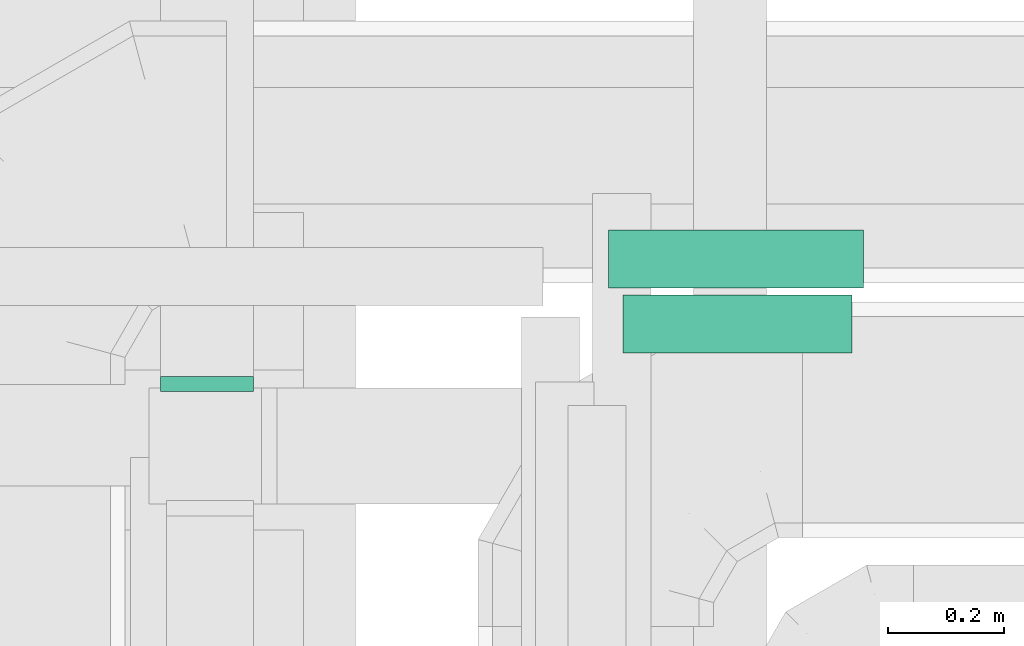
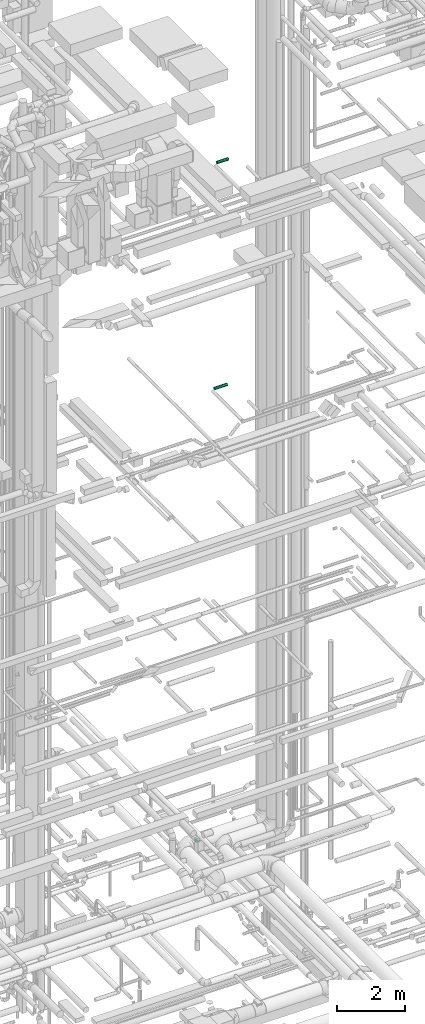
# One storey, part 268 of 337: 2 flow segments, 1 flow fitting.
"""IFC2X3 building model written with IfcOpenShell, lengths in millimetres."""

from ifc_helpers import new_model, entity, si_unit, converted_unit, derived_unit, direction, frame, origin, origin_2d_with_axis, place, context, subcontext, project, spatial, circle, extrude, faceted_brep, source, transform, mapped, material, type_object, type_shapes, element, save


model = new_model("IFC2X3")

# Units and contexts
model_context = context("Model", 3, precision=0.01, world=origin(), true_north=direction((6.12303176911189e-17, 1.0)))
body_context = subcontext(model_context, "Body", "Model", "MODEL_VIEW")
ifc_project = project(units=[si_unit("LENGTHUNIT", "METRE", prefix="MILLI"), si_unit("AREAUNIT", "SQUARE_METRE"), si_unit("VOLUMEUNIT", "CUBIC_METRE"), converted_unit("PLANEANGLEUNIT", "DEGREE", entity("IfcRatioMeasure", 0.0174532925199433), si_unit("PLANEANGLEUNIT", "RADIAN"), dimensions=[0, 0, 0, 0, 0, 0, 0]), si_unit("MASSUNIT", "GRAM", prefix="KILO"), derived_unit("MASSDENSITYUNIT", [(si_unit("MASSUNIT", "GRAM", prefix="KILO"), 1), (si_unit("LENGTHUNIT", "METRE"), -3)]), derived_unit("MOMENTOFINERTIAUNIT", [(si_unit("LENGTHUNIT", "METRE"), 4)]), si_unit("TIMEUNIT", "SECOND"), si_unit("FREQUENCYUNIT", "HERTZ"), si_unit("THERMODYNAMICTEMPERATUREUNIT", "DEGREE_CELSIUS"), derived_unit("THERMALTRANSMITTANCEUNIT", [(si_unit("MASSUNIT", "GRAM", prefix="KILO"), 1), (si_unit("THERMODYNAMICTEMPERATUREUNIT", "KELVIN"), -1), (si_unit("TIMEUNIT", "SECOND"), -3)]), derived_unit("VOLUMETRICFLOWRATEUNIT", [(si_unit("LENGTHUNIT", "METRE"), 3), (si_unit("TIMEUNIT", "SECOND"), -1)]), derived_unit("MASSFLOWRATEUNIT", [(si_unit("MASSUNIT", "GRAM", prefix="KILO"), 1), (si_unit("TIMEUNIT", "SECOND"), -1)]), derived_unit("ROTATIONALFREQUENCYUNIT", [(si_unit("TIMEUNIT", "SECOND"), -1)]), si_unit("ELECTRICCURRENTUNIT", "AMPERE"), si_unit("ELECTRICVOLTAGEUNIT", "VOLT"), si_unit("POWERUNIT", "WATT"), si_unit("FORCEUNIT", "NEWTON", prefix="KILO"), si_unit("ILLUMINANCEUNIT", "LUX"), si_unit("LUMINOUSFLUXUNIT", "LUMEN"), si_unit("LUMINOUSINTENSITYUNIT", "CANDELA"), derived_unit("USERDEFINED", [(si_unit("MASSUNIT", "GRAM", prefix="KILO"), -1), (si_unit("LENGTHUNIT", "METRE"), -2), (si_unit("TIMEUNIT", "SECOND"), 3), (si_unit("LUMINOUSFLUXUNIT", "LUMEN"), 1)]), derived_unit("LINEARVELOCITYUNIT", [(si_unit("LENGTHUNIT", "METRE"), 1), (si_unit("TIMEUNIT", "SECOND"), -1)]), si_unit("PRESSUREUNIT", "PASCAL"), derived_unit("USERDEFINED", [(si_unit("LENGTHUNIT", "METRE"), -2), (si_unit("MASSUNIT", "GRAM", prefix="KILO"), 1), (si_unit("TIMEUNIT", "SECOND"), -2)]), derived_unit("LINEARFORCEUNIT", [(si_unit("MASSUNIT", "GRAM", prefix="KILO"), 1), (si_unit("LENGTHUNIT", "METRE"), 1), (si_unit("TIMEUNIT", "SECOND"), -2), (si_unit("LENGTHUNIT", "METRE"), -1)]), derived_unit("PLANARFORCEUNIT", [(si_unit("MASSUNIT", "GRAM", prefix="KILO"), 1), (si_unit("LENGTHUNIT", "METRE"), 1), (si_unit("TIMEUNIT", "SECOND"), -2), (si_unit("LENGTHUNIT", "METRE"), -2)])], contexts=[model_context])

# Site, building, storey
site_placement = place(None, origin())
site = spatial("IfcSite", under=ifc_project, at=site_placement, CompositionType="ELEMENT")
building_placement = place(site_placement, origin())
building = spatial("IfcBuilding", under=site, at=building_placement, CompositionType="ELEMENT")
storey_placement = place(building_placement, origin())
storey = spatial("IfcBuildingStorey", under=building, at=storey_placement, CompositionType="ELEMENT", Elevation=0.0)

# Flow segments
duct_segment_type = type_object("IfcDuctSegmentType", PredefinedType="NOTDEFINED")
flow_segment_1_placement = place(storey_placement, frame((65705.0, 12014.33, 19148.4)))
element("IfcFlowSegment", 1, at=flow_segment_1_placement, inside=storey, type_object=duct_segment_type, context=body_context, shape_type="SweptSolid", body=[
    extrude(circle(Radius=50.0, at=origin_2d_with_axis()), frame((0.0, 51.6, 51.6), z_axis=(1.0, 0.0, 0.0), x_axis=(0.0, -1.0, 0.0)), (0.0, 0.0, 1.0), 438.437500000021),
])
flow_segment_2_placement = place(storey_placement, frame((65729.62, 11902.79, 27308.4)))
element("IfcFlowSegment", 2, at=flow_segment_2_placement, inside=storey, type_object=duct_segment_type, context=body_context, shape_type="SweptSolid", body=[
    extrude(circle(Radius=50.0, at=origin_2d_with_axis()), frame((0.0, 51.6, 51.6), z_axis=(1.0, 0.0, 0.0), x_axis=(0.0, -1.0, 0.0)), (0.0, 0.0, 1.0), 393.749999999941),
])

# Flow fitting
ifc_material = material()
duct_fitting_type = type_object("IfcDuctFittingType", PredefinedType="NOTDEFINED", material=ifc_material)
shared_shape = source(origin(), body_context, "Body", "Brep", [
    faceted_brep([(20.0, 20.71, -77.27), (20.0, 40.0, -69.28), (20.0, 56.57, -56.57), (20.0, 69.28, -40.0), (20.0, 77.27, -20.71), (20.0, 80.0, 0.0), (20.0, 77.27, 20.71), (20.0, 69.28, 40.0), (20.0, 56.57, 56.57), (20.0, 40.0, 69.28), (20.0, 20.71, 77.27), (20.0, 0.0, 80.0), (20.0, -20.71, 77.27), (20.0, -40.0, 69.28), (20.0, -56.57, 56.57), (20.0, -69.28, 40.0), (20.0, -77.27, 20.71), (20.0, -80.0, 0.0), (20.0, -77.27, -20.71), (20.0, -69.28, -40.0), (20.0, -56.57, -56.57), (20.0, -40.0, -69.28), (20.0, -20.71, -77.27), (20.0, 0.0, -80.0), (0.0, 0.0, 80.0), (0.0, 20.71, 77.27), (-6.1, 20.71, 77.27), (-6.1, 0.0, 80.0), (0.0, 40.0, 69.28), (-6.1, 40.0, 69.28), (0.0, 56.57, 56.57), (-6.1, 56.57, 56.57), (0.0, 69.28, 40.0), (0.0, 77.27, 20.71), (-6.1, 77.27, 20.71), (-6.1, 69.28, 40.0), (0.0, 80.0, 0.0), (-6.1, 80.0, 0.0), (0.0, 77.27, -20.71), (-6.1, 77.27, -20.71), (0.0, 69.28, -40.0), (-6.1, 69.28, -40.0), (0.0, 56.57, -56.57), (-6.1, 56.57, -56.57), (0.0, 40.0, -69.28), (0.0, 20.71, -77.27), (-6.1, 20.71, -77.27), (-6.1, 40.0, -69.28), (0.0, 0.0, -80.0), (-6.1, 0.0, -80.0), (0.0, -20.71, -77.27), (-6.1, -20.71, -77.27), (0.0, -40.0, -69.28), (-6.1, -40.0, -69.28), (0.0, -56.57, -56.57), (-6.1, -56.57, -56.57), (0.0, -69.28, -40.0), (0.0, -77.27, -20.71), (-6.1, -77.27, -20.71), (-6.1, -69.28, -40.0), (0.0, -80.0, 0.0), (-6.1, -80.0, 0.0), (0.0, -77.27, 20.71), (-6.1, -77.27, 20.71), (0.0, -69.28, 40.0), (-6.1, -69.28, 40.0), (0.0, -56.57, 56.57), (-6.1, -56.57, 56.57), (0.0, -40.0, 69.28), (0.0, -20.71, 77.27), (-6.1, -20.71, 77.27), (-6.1, -40.0, 69.28)], [[[0, 1, 2, 3, 4, 5, 6, 7, 8, 9, 10, 11, 12, 13, 14, 15, 16, 17, 18, 19, 20, 21, 22, 23]], [[24, 11, 10, 25, 26, 27]], [[25, 10, 9, 28, 29, 26]], [[28, 9, 8, 30, 31, 29]], [[32, 7, 6, 33, 34, 35]], [[33, 6, 5, 36, 37, 34]], [[30, 8, 7, 32, 35, 31]], [[36, 5, 4, 38, 39, 37]], [[38, 4, 3, 40, 41, 39]], [[40, 3, 2, 42, 43, 41]], [[44, 1, 0, 45, 46, 47]], [[45, 0, 23, 48, 49, 46]], [[42, 2, 1, 44, 47, 43]], [[48, 23, 22, 50, 51, 49]], [[50, 22, 21, 52, 53, 51]], [[52, 21, 20, 54, 55, 53]], [[56, 19, 18, 57, 58, 59]], [[57, 18, 17, 60, 61, 58]], [[54, 20, 19, 56, 59, 55]], [[60, 17, 16, 62, 63, 61]], [[62, 16, 15, 64, 65, 63]], [[64, 15, 14, 66, 67, 65]], [[68, 13, 12, 69, 70, 71]], [[69, 12, 11, 24, 27, 70]], [[66, 14, 13, 68, 71, 67]], [[49, 51, 53, 55, 59, 58, 61, 63, 65, 67, 71, 70, 27, 26, 29, 31, 35, 34, 37, 39, 41, 43, 47, 46]]]),
])
type_shapes(duct_fitting_type, [shared_shape])
flow_fitting_placement = place(storey_placement, frame((65014.49, 11844.28, 3380.0), z_axis=(1.0, 0.0, 0.0), x_axis=(0.0, 1.0, 0.0)))
element("IfcFlowFitting", 3, at=flow_fitting_placement, inside=storey, type_object=duct_fitting_type, material=ifc_material, context=body_context, shape_type="MappedRepresentation", body=[
    mapped(shared_shape, transform((0.0, 0.0, 0.0), scale=1.0)),
])

save(model, "model.ifc")
